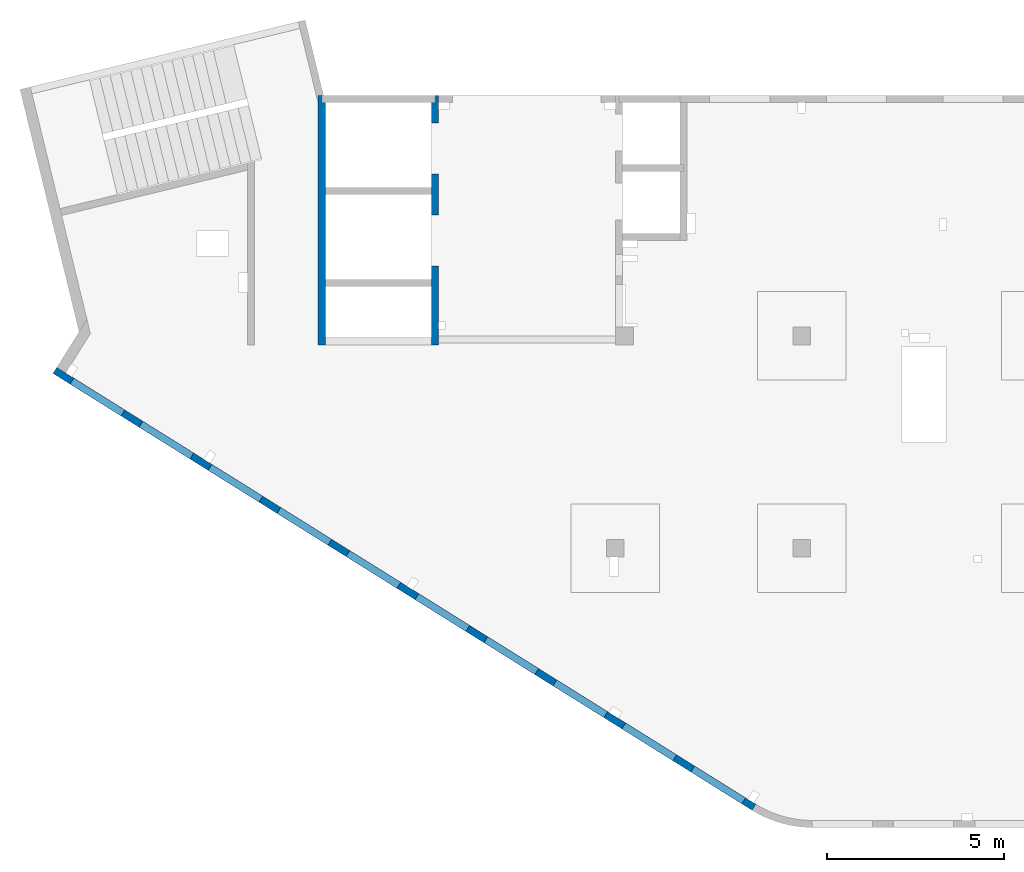
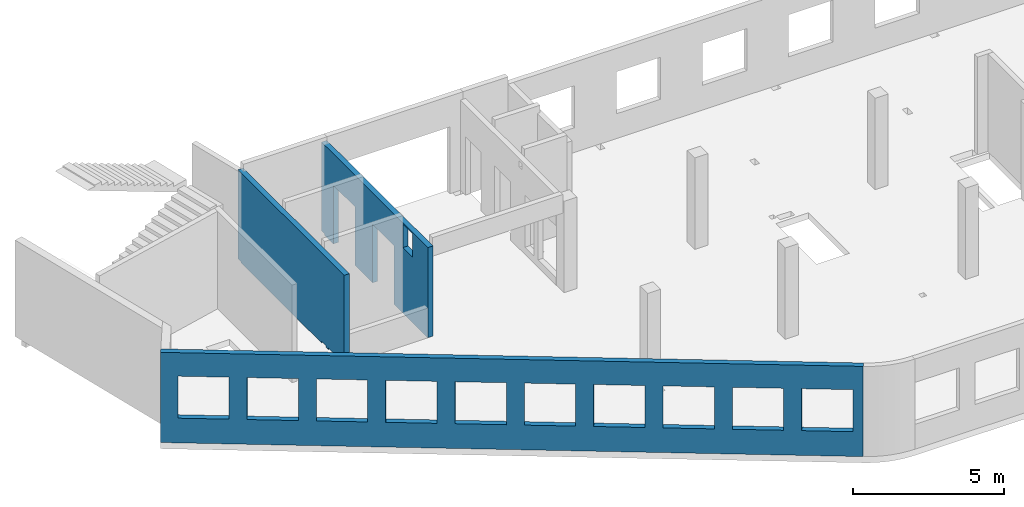
# One storey, part 4 of 7: 3 walls, 17 openings.
"""IFC4 building model written with IfcOpenShell, lengths in millimetres."""

from ifc_helpers import new_model, entity, si_unit, converted_unit, derived_unit, direction, frame, origin, place, context, subcontext, project, spatial, indexed_curve, outline, extrude, polygons, material, type_object, element, save


model = new_model("IFC4")

# Units and contexts
model_context = context("Model", 3, precision=0.01, world=origin(), true_north=direction((6.12303176911189e-17, 1.0)))
plan_context = context("Plan", 3, precision=0.01, world=origin(), true_north=direction((6.12303176911189e-17, 1.0)))
body_context = subcontext(model_context, "Body", "Model", "MODEL_VIEW")
ifc_project = project(units=[si_unit("LENGTHUNIT", "METRE", prefix="MILLI"), si_unit("AREAUNIT", "SQUARE_METRE"), si_unit("VOLUMEUNIT", "CUBIC_METRE"), converted_unit("PLANEANGLEUNIT", "DEGREE", entity("IfcRatioMeasure", 0.0174532925199433), si_unit("PLANEANGLEUNIT", "RADIAN"), dimensions=[0, 0, 0, 0, 0, 0, 0]), si_unit("MASSUNIT", "GRAM", prefix="KILO"), derived_unit("MASSDENSITYUNIT", [(si_unit("MASSUNIT", "GRAM", prefix="KILO"), 1), (si_unit("LENGTHUNIT", "METRE"), -3)]), derived_unit("MOMENTOFINERTIAUNIT", [(si_unit("LENGTHUNIT", "METRE"), 4)]), si_unit("TIMEUNIT", "SECOND"), si_unit("FREQUENCYUNIT", "HERTZ"), si_unit("THERMODYNAMICTEMPERATUREUNIT", "DEGREE_CELSIUS"), derived_unit("THERMALTRANSMITTANCEUNIT", [(si_unit("MASSUNIT", "GRAM", prefix="KILO"), 1), (si_unit("THERMODYNAMICTEMPERATUREUNIT", "KELVIN"), -1), (si_unit("TIMEUNIT", "SECOND"), -3)]), derived_unit("VOLUMETRICFLOWRATEUNIT", [(si_unit("LENGTHUNIT", "METRE"), 3), (si_unit("TIMEUNIT", "SECOND"), -1)]), derived_unit("MASSFLOWRATEUNIT", [(si_unit("MASSUNIT", "GRAM", prefix="KILO"), 1), (si_unit("TIMEUNIT", "SECOND"), -1)]), derived_unit("ROTATIONALFREQUENCYUNIT", [(si_unit("TIMEUNIT", "SECOND"), -1)]), si_unit("ELECTRICCURRENTUNIT", "AMPERE"), si_unit("ELECTRICVOLTAGEUNIT", "VOLT"), si_unit("POWERUNIT", "WATT"), si_unit("FORCEUNIT", "NEWTON", prefix="KILO"), si_unit("ILLUMINANCEUNIT", "LUX"), si_unit("LUMINOUSFLUXUNIT", "LUMEN"), si_unit("LUMINOUSINTENSITYUNIT", "CANDELA"), derived_unit("USERDEFINED", [(si_unit("MASSUNIT", "GRAM", prefix="KILO"), -1), (si_unit("LENGTHUNIT", "METRE"), -2), (si_unit("TIMEUNIT", "SECOND"), 3), (si_unit("LUMINOUSFLUXUNIT", "LUMEN"), 1)]), derived_unit("LINEARVELOCITYUNIT", [(si_unit("LENGTHUNIT", "METRE"), 1), (si_unit("TIMEUNIT", "SECOND"), -1)]), si_unit("PRESSUREUNIT", "PASCAL"), derived_unit("USERDEFINED", [(si_unit("LENGTHUNIT", "METRE"), -2), (si_unit("MASSUNIT", "GRAM", prefix="KILO"), 1), (si_unit("TIMEUNIT", "SECOND"), -2)]), derived_unit("LINEARFORCEUNIT", [(si_unit("MASSUNIT", "GRAM", prefix="KILO"), 1), (si_unit("LENGTHUNIT", "METRE"), 1), (si_unit("TIMEUNIT", "SECOND"), -2), (si_unit("LENGTHUNIT", "METRE"), -1)]), derived_unit("PLANARFORCEUNIT", [(si_unit("MASSUNIT", "GRAM", prefix="KILO"), 1), (si_unit("LENGTHUNIT", "METRE"), 1), (si_unit("TIMEUNIT", "SECOND"), -2), (si_unit("LENGTHUNIT", "METRE"), -2)])], contexts=[model_context, plan_context])

# Site, building, storey
site_placement = place(None, origin())
site = spatial("IfcSite", under=ifc_project, at=site_placement, CompositionType="ELEMENT")
building_placement = place(site_placement, origin())
building = spatial("IfcBuilding", under=site, at=building_placement, CompositionType="ELEMENT")
storey_placement = place(building_placement, frame((0.0, 0.0, 12000.0)))
storey = spatial("IfcBuildingStorey", under=building, at=storey_placement, CompositionType="ELEMENT", Elevation=12000.0)

# Wall, openings
ifc_material = material()
wall_type = type_object("IfcWallType", PredefinedType="STANDARD")
wall_1_placement = place(storey_placement, frame((19822.3508929728, 371.159406986362, -150.0), z_axis=(0.0, 0.0, 1.0), x_axis=(-0.848052743777574, 0.529911826412025, 0.0)))
wall_1 = element("IfcWall", 1, at=wall_1_placement, inside=storey, type_object=wall_type, material=ifc_material, PredefinedType="NOTDEFINED", context=body_context, shape_type="Tessellation", body=[
    polygons([(-1.48894230278529e-12, -99.9999999999978, 0.0), (23011.6394501553, -99.9999999999989, 0.0), (23311.6394501553, -99.9999999999989, 0.0), (23311.6394501553, -99.9999999999989, 3650.0), (23011.6394501553, -99.9999999999989, 3650.0), (-1.48894230278529e-12, -99.9999999999978, 3650.0), (341.63903172165, -99.9999999999988, 2699.99999999999), (2041.63903172165, -99.9999999999981, 2699.99999999999), (2041.63903172165, -99.9999999999981, 1000.00000000001), (341.63903172165, -99.9999999999988, 1000.00000000001), (2641.63903172165, -99.9999999999995, 2699.99999999999), (4341.63903172165, -99.9999999999992, 2699.99999999999), (4341.63903172165, -99.9999999999992, 1000.00000000001), (2641.63903172165, -99.9999999999995, 1000.00000000001), (4941.63903172166, -100.0, 2699.99999999999), (6641.63903172166, -99.9999999999984, 2699.99999999999), (6641.63903172166, -99.9999999999984, 1000.00000000001), (4941.63903172166, -100.0, 1000.00000000001), (7241.63903172167, -99.9999999999984, 2699.99999999999), (8941.63903172167, -100.0, 2699.99999999999), (8941.63903172167, -100.0, 1000.00000000001), (7241.63903172167, -99.9999999999984, 1000.00000000001), (9541.63903172167, -100.0, 2699.99999999999), (11241.6390317217, -99.9999999999989, 2699.99999999999), (11241.6390317217, -99.9999999999989, 1000.00000000001), (9541.63903172167, -100.0, 1000.00000000001), (11841.6390317217, -100.0, 2699.99999999999), (13541.6390317217, -100.0, 2699.99999999999), (13541.6390317217, -100.0, 1000.00000000001), (11841.6390317217, -100.0, 1000.00000000001), (14141.6390317217, -100.0, 2699.99999999999), (15841.6390317217, -100.0, 2699.99999999999), (15841.6390317217, -100.0, 1000.00000000001), (14141.6390317217, -100.0, 1000.00000000001), (16441.6390317217, -99.9999999999989, 2699.99999999999), (18141.6390317217, -99.9999999999989, 2699.99999999999), (18141.6390317217, -99.9999999999989, 1000.00000000001), (16441.6390317217, -99.9999999999989, 1000.00000000001), (18741.6390317217, -100.0, 2699.99999999999), (20441.6390317217, -99.9999999999989, 2699.99999999999), (20441.6390317217, -99.9999999999989, 1000.00000000001), (18741.6390317217, -100.0, 1000.00000000001), (21041.6390317217, -99.9999999999989, 2699.99999999999), (22741.6390317217, -100.000000000001, 2699.99999999999), (22741.6390317217, -100.000000000001, 1000.00000000001), (21041.6390317217, -99.9999999999989, 1000.00000000001), (23311.6394501553, 99.9999999999989, 0.0), (-2.26725305196851e-12, 100.000000000001, 0.0), (-2.26725305196851e-12, 100.000000000001, 3650.0), (23311.6394501553, 100.000000000001, 3650.0), (2041.63903172165, 100.000000000323, 2700.0), (341.63903172165, 100.000000000321, 2700.0), (341.63903172165, 100.000000000321, 1000.00000000001), (2041.63903172165, 100.000000000323, 1000.00000000001), (4341.63903172165, 100.000000000322, 2700.0), (2641.63903172165, 100.00000000032, 2700.0), (2641.63903172165, 100.00000000032, 1000.00000000001), (4341.63903172165, 100.000000000322, 1000.00000000001), (6641.63903172166, 100.000000000322, 2700.0), (4941.63903172166, 100.000000000321, 2700.0), (4941.63903172166, 100.000000000321, 1000.00000000001), (6641.63903172166, 100.000000000322, 1000.00000000001), (8941.63903172166, 100.000000000321, 2700.0), (7241.63903172167, 100.000000000322, 2700.0), (7241.63903172167, 100.000000000322, 1000.00000000001), (8941.63903172166, 100.000000000321, 1000.00000000001), (11241.6390317217, 100.000000000323, 2700.0), (9541.63903172167, 100.000000000321, 2700.0), (9541.63903172167, 100.000000000321, 1000.00000000001), (11241.6390317217, 100.000000000323, 1000.00000000001), (13541.6390317217, 100.000000000319, 2700.0), (11841.6390317217, 100.000000000323, 2700.0), (11841.6390317217, 100.000000000323, 1000.00000000001), (13541.6390317217, 100.000000000319, 1000.00000000001), (15841.6390317217, 100.000000000322, 2700.0), (14141.6390317217, 100.000000000322, 2700.0), (14141.6390317217, 100.000000000322, 1000.00000000001), (15841.6390317217, 100.000000000322, 1000.00000000001), (18141.6390317217, 100.000000000322, 2700.0), (16441.6390317217, 100.000000000322, 2700.0), (16441.6390317217, 100.000000000322, 1000.00000000001), (18141.6390317217, 100.000000000322, 1000.00000000001), (20441.6390317217, 100.000000000322, 2700.0), (18741.6390317217, 100.000000000319, 2700.0), (18741.6390317217, 100.000000000319, 1000.00000000001), (20441.6390317217, 100.000000000322, 1000.00000000001), (22741.6390317217, 100.000000000319, 2700.0), (21041.6390317217, 100.000000000321, 2700.0), (21041.6390317217, 100.000000000323, 1000.00000000001), (22741.6390317217, 100.000000000319, 1000.00000000001)], [[[1, 2, 3, 4, 5, 6], [7, 8, 9, 10], [11, 12, 13, 14], [15, 16, 17, 18], [19, 20, 21, 22], [23, 24, 25, 26], [27, 28, 29, 30], [31, 32, 33, 34], [35, 36, 37, 38], [39, 40, 41, 42], [43, 44, 45, 46]], [[47, 48, 49, 50], [51, 52, 53, 54], [55, 56, 57, 58], [59, 60, 61, 62], [63, 64, 65, 66], [67, 68, 69, 70], [71, 72, 73, 74], [75, 76, 77, 78], [79, 80, 81, 82], [83, 84, 85, 86], [87, 88, 89, 90]], [[3, 2, 1, 48, 47]], [[6, 5, 4, 50, 49]], [[1, 6, 49, 48]], [[4, 3, 47, 50]], [[52, 51, 8, 7]], [[52, 7, 10, 53]], [[53, 10, 9, 54]], [[8, 51, 54, 9]], [[56, 55, 12, 11]], [[56, 11, 14, 57]], [[57, 14, 13, 58]], [[12, 55, 58, 13]], [[60, 59, 16, 15]], [[60, 15, 18, 61]], [[61, 18, 17, 62]], [[16, 59, 62, 17]], [[64, 63, 20, 19]], [[64, 19, 22, 65]], [[65, 22, 21, 66]], [[20, 63, 66, 21]], [[68, 67, 24, 23]], [[68, 23, 26, 69]], [[69, 26, 25, 70]], [[24, 67, 70, 25]], [[72, 71, 28, 27]], [[72, 27, 30, 73]], [[73, 30, 29, 74]], [[28, 71, 74, 29]], [[76, 75, 32, 31]], [[76, 31, 34, 77]], [[77, 34, 33, 78]], [[32, 75, 78, 33]], [[80, 79, 36, 35]], [[80, 35, 38, 81]], [[81, 38, 37, 82]], [[36, 79, 82, 37]], [[84, 83, 40, 39]], [[84, 39, 42, 85]], [[85, 42, 41, 86]], [[40, 83, 86, 41]], [[88, 87, 44, 43]], [[88, 43, 46, 89]], [[89, 46, 45, 90]], [[44, 87, 90, 45]]], closed=True),
])
opening_1_placement = place(wall_1_placement, frame((16613.7173036613, 10818.8609189489, 150.0), z_axis=(0.0, 0.0, 1.0), x_axis=(-0.848052743777574, -0.529911826412026, 0.0)))
element("IfcOpeningElement", 2, at=opening_1_placement, cuts=wall_1, PredefinedType="OPENING", context=body_context, shape_type="SweptSolid", body=[
    extrude(outline(indexed_curve([(-849.999999999993, -850.0), (849.999999999995, -850.0), (849.999999999995, 850.0), (-849.999999999993, 850.0), (-849.999999999993, -850.0)], self_intersect=False)), frame((1310.07752897417, 12056.6031038165, 1700.0), z_axis=(-0.529911826412026, -0.848052743777574, 0.0), x_axis=(0.0, 0.0, -1.0)), (0.0, 0.0, 1.0), 200.000000000964),
])
opening_2_placement = place(wall_1_placement, frame((16613.7173036613, 10818.8609189489, 150.0), z_axis=(0.0, 0.0, 1.0), x_axis=(-0.848052743777574, -0.529911826412026, 0.0)))
element("IfcOpeningElement", 3, at=opening_2_placement, cuts=wall_1, PredefinedType="OPENING", context=body_context, shape_type="SweptSolid", body=[
    extrude(outline(indexed_curve([(-849.999999999993, -850.0), (849.999999999995, -850.0), (849.999999999995, 850.0), (-849.999999999993, 850.0), (-849.999999999993, -850.0)], self_intersect=False)), frame((3260.5988396626, 10837.8059030689, 1700.0), z_axis=(-0.529911826412026, -0.848052743777574, 0.0), x_axis=(0.0, 0.0, -1.0)), (0.0, 0.0, 1.0), 200.000000000964),
])
opening_3_placement = place(wall_1_placement, frame((16613.7173036613, 10818.8609189489, 150.0), z_axis=(0.0, 0.0, 1.0), x_axis=(-0.848052743777574, -0.529911826412026, 0.0)))
element("IfcOpeningElement", 4, at=opening_3_placement, cuts=wall_1, PredefinedType="OPENING", context=body_context, shape_type="SweptSolid", body=[
    extrude(outline(indexed_curve([(-849.999999999993, -850.0), (849.999999999995, -850.0), (849.999999999995, 850.0), (-849.999999999993, 850.0), (-849.999999999993, -850.0)], self_intersect=False)), frame((5211.12015035101, 9619.00870232123, 1700.0), z_axis=(-0.529911826412025, -0.848052743777574, 0.0), x_axis=(0.0, 0.0, -1.0)), (0.0, 0.0, 1.0), 200.000000000962),
])
opening_4_placement = place(wall_1_placement, frame((16613.7173036613, 10818.8609189489, 150.0), z_axis=(0.0, 0.0, 1.0), x_axis=(-0.848052743777574, -0.529911826412026, 0.0)))
element("IfcOpeningElement", 5, at=opening_4_placement, cuts=wall_1, PredefinedType="OPENING", context=body_context, shape_type="SweptSolid", body=[
    extrude(outline(indexed_curve([(-849.999999999993, -849.999999999999), (849.999999999995, -849.999999999999), (849.999999999995, 850.0), (-849.999999999993, 850.0), (-849.999999999993, -849.999999999999)], self_intersect=False)), frame((7161.64146103944, 8400.21150157357, 1700.0), z_axis=(-0.529911826412026, -0.848052743777574, 0.0), x_axis=(0.0, 0.0, -1.0)), (0.0, 0.0, 1.0), 200.000000000962),
])
opening_5_placement = place(wall_1_placement, frame((16613.7173036613, 10818.8609189489, 150.0), z_axis=(0.0, 0.0, 1.0), x_axis=(-0.848052743777574, -0.529911826412026, 0.0)))
element("IfcOpeningElement", 6, at=opening_5_placement, cuts=wall_1, PredefinedType="OPENING", context=body_context, shape_type="SweptSolid", body=[
    extrude(outline(indexed_curve([(-849.999999999993, -849.999999999999), (849.999999999995, -849.999999999999), (849.999999999995, 850.0), (-849.999999999993, 850.0), (-849.999999999993, -849.999999999999)], self_intersect=False)), frame((9112.16277172786, 7181.41430082591, 1700.0), z_axis=(-0.529911826412026, -0.848052743777574, 0.0), x_axis=(0.0, 0.0, -1.0)), (0.0, 0.0, 1.0), 200.000000000962),
])
opening_6_placement = place(wall_1_placement, frame((16613.7173036613, 10818.8609189489, 150.0), z_axis=(0.0, 0.0, 1.0), x_axis=(-0.848052743777574, -0.529911826412026, 0.0)))
element("IfcOpeningElement", 7, at=opening_6_placement, cuts=wall_1, PredefinedType="OPENING", context=body_context, shape_type="SweptSolid", body=[
    extrude(outline(indexed_curve([(-849.999999999993, -850.0), (849.999999999995, -850.0), (849.999999999995, 850.0), (-849.999999999993, 850.0), (-849.999999999993, -850.0)], self_intersect=False)), frame((11062.6840824163, 5962.61710007824, 1700.0), z_axis=(-0.529911826412025, -0.848052743777574, 0.0), x_axis=(0.0, 0.0, -1.0)), (0.0, 0.0, 1.0), 200.000000000964),
])
opening_7_placement = place(wall_1_placement, frame((16613.7173036613, 10818.8609189489, 150.0), z_axis=(0.0, 0.0, 1.0), x_axis=(-0.848052743777574, -0.529911826412026, 0.0)))
element("IfcOpeningElement", 8, at=opening_7_placement, cuts=wall_1, PredefinedType="OPENING", context=body_context, shape_type="SweptSolid", body=[
    extrude(outline(indexed_curve([(-849.999999999993, -850.0), (849.999999999995, -850.0), (849.999999999995, 850.0), (-849.999999999993, 850.0), (-849.999999999993, -850.0)], self_intersect=False)), frame((13013.2053931047, 4743.81989933058, 1700.0), z_axis=(-0.529911826412025, -0.848052743777574, 0.0), x_axis=(0.0, 0.0, -1.0)), (0.0, 0.0, 1.0), 200.000000000959),
])
opening_8_placement = place(wall_1_placement, frame((16613.7173036613, 10818.8609189489, 150.0), z_axis=(0.0, 0.0, 1.0), x_axis=(-0.848052743777574, -0.529911826412026, 0.0)))
element("IfcOpeningElement", 9, at=opening_8_placement, cuts=wall_1, PredefinedType="OPENING", context=body_context, shape_type="SweptSolid", body=[
    extrude(outline(indexed_curve([(-849.999999999993, -850.000000000002), (849.999999999995, -850.000000000002), (849.999999999995, 849.999999999998), (-849.999999999993, 849.999999999998), (-849.999999999993, -850.000000000002)], self_intersect=False)), frame((14963.7267037931, 3525.02269858292, 1700.0), z_axis=(-0.529911826412025, -0.848052743777574, 0.0), x_axis=(0.0, 0.0, -1.0)), (0.0, 0.0, 1.0), 200.000000000962),
])
opening_9_placement = place(wall_1_placement, frame((16613.7173036613, 10818.8609189489, 150.0), z_axis=(0.0, 0.0, 1.0), x_axis=(-0.848052743777574, -0.529911826412026, 0.0)))
element("IfcOpeningElement", 10, at=opening_9_placement, cuts=wall_1, PredefinedType="OPENING", context=body_context, shape_type="SweptSolid", body=[
    extrude(outline(indexed_curve([(-849.999999999993, -850.0), (849.999999999995, -850.0), (849.999999999995, 850.0), (-849.999999999993, 850.0), (-849.999999999993, -850.0)], self_intersect=False)), frame((16914.2480144816, 2306.22549783526, 1700.0), z_axis=(-0.529911826412025, -0.848052743777574, 0.0), x_axis=(0.0, 0.0, -1.0)), (0.0, 0.0, 1.0), 200.000000000962),
])
opening_10_placement = place(wall_1_placement, frame((16613.7173036613, 10818.8609189489, 150.0), z_axis=(0.0, 0.0, 1.0), x_axis=(-0.848052743777574, -0.529911826412026, 0.0)))
element("IfcOpeningElement", 11, at=opening_10_placement, cuts=wall_1, PredefinedType="OPENING", context=body_context, shape_type="SweptSolid", body=[
    extrude(outline(indexed_curve([(-849.999999999993, -850.0), (849.999999999995, -850.0), (849.999999999995, 850.0), (-849.999999999993, 850.0), (-849.999999999993, -850.0)], self_intersect=False)), frame((18864.76932517, 1087.4282970876, 1700.0), z_axis=(-0.529911826412025, -0.848052743777574, 0.0), x_axis=(0.0, 0.0, -1.0)), (0.0, 0.0, 1.0), 200.000000000966),
])

wall_2_placement = place(storey_placement, frame((7600.0002685547, 20499.9998657227, -150.0), z_axis=(0.0, 0.0, 1.0), x_axis=(0.0, -1.0, 0.0)))
wall_2 = element("IfcWall", 12, at=wall_2_placement, inside=storey, type_object=wall_type, material=ifc_material, PredefinedType="NOTDEFINED", context=body_context, shape_type="Tessellation", body=[
    polygons([(7050.0006393668, -99.9999999999996, 3650.0), (226.500105821614, -99.9999999999996, 3650.0), (0.0, -100.000000000001, 3650.0), (0.0, -100.000000000001, 49.9999999999973), (200.000000000002, -100.000000000001, 49.9999999999973), (200.000000000002, -100.000000000001, 0.0), (226.50010582161, -99.9999999999996, 0.0), (5545.0, -100.000000000001, 0.0), (5545.0, -100.000000000001, 59.999999999995), (5855.0, -100.0, 59.999999999995), (5855.0, -100.0, 0.0), (5985.0, -100.0, 0.0), (5985.0, -100.0, 59.999999999995), (6294.99999999999, -99.9999999999997, 59.999999999995), (6294.99999999999, -99.9999999999997, 0.0), (7050.0006393668, -99.9999999999996, 0.0), (0.0, 100.0, 3650.0), (200.000000000002, 100.0, 3650.0), (6850.0006393668, 100.0, 3650.0), (7050.0006393668, 99.9999999999993, 3650.0), (7050.0006393668, 100.0, 1200.0), (7050.0006393668, 99.9999999999993, 0.0), (6850.0006393668, 100.0, 0.0), (6294.99999999999, 100.0, 0.0), (6294.99999999999, 100.000000000321, 59.999999999995), (5985.0, 100.000000000321, 59.999999999995), (5985.0, 100.000000000001, 0.0), (5855.0, 100.000000000001, 0.0), (5855.0, 100.000000000321, 59.999999999995), (5545.0, 100.000000000321, 59.999999999995), (5545.0, 100.0, 0.0), (200.000000000002, 100.0, 0.0), (200.000000000002, 100.0, 49.9999999999973), (0.0, 100.0, 49.9999999999973), (200.000000000002, -6.87656940234796e-13, 0.0), (0.0, 50.6443876577722, 3650.0), (0.0, 7.9044633377313e-14, 3650.0)], [[[1, 2, 3, 4, 5, 6, 7, 8, 9, 10, 11, 12, 13, 14, 15, 16]], [[17, 18, 19, 20, 21, 22, 23, 24, 25, 26, 27, 28, 29, 30, 31, 32, 33, 34]], [[6, 35, 32, 31, 8, 7]], [[3, 2, 1, 20, 19, 18, 17, 36, 37]], [[6, 5, 33, 32, 35]], [[4, 3, 37, 36, 17, 34]], [[13, 26, 25, 14]], [[26, 13, 12, 27]], [[14, 25, 24, 15]], [[9, 30, 29, 10]], [[30, 9, 8, 31]], [[10, 29, 28, 11]], [[34, 33, 5, 4]], [[1, 16, 22, 21, 20]], [[16, 15, 24, 23, 22]], [[27, 12, 11, 28]]], closed=True),
])
opening_11_placement = place(wall_2_placement, origin())
element("IfcOpeningElement", 13, at=opening_11_placement, cuts=wall_2, PredefinedType="OPENING", context=body_context, shape_type="SweptSolid", body=[
    extrude(outline(indexed_curve([(-154.999999999993, -154.999999999999), (154.999999999993, -154.999999999999), (154.999999999993, 154.999999999999), (-154.999999999993, 154.999999999999), (-154.999999999993, -154.999999999999)], self_intersect=False)), frame((6140.0, -100.0, -95.0), z_axis=(0.0, 1.0, 0.0), x_axis=(0.0, 0.0, -1.0)), (0.0, 0.0, 1.0), 200.000000000962),
])
opening_12_placement = place(wall_2_placement, origin())
element("IfcOpeningElement", 14, at=opening_12_placement, cuts=wall_2, PredefinedType="OPENING", context=body_context, shape_type="SweptSolid", body=[
    extrude(outline(indexed_curve([(-154.999999999993, -154.999999999999), (154.999999999993, -154.999999999999), (154.999999999993, 154.999999999999), (-154.999999999993, 154.999999999999), (-154.999999999993, -154.999999999999)], self_intersect=False)), frame((5700.0, -100.0, -95.0), z_axis=(0.0, 1.0, 0.0), x_axis=(0.0, 0.0, -1.0)), (0.0, 0.0, 1.0), 200.000000000962),
])
opening_13_placement = place(wall_2_placement, frame((20499.9998657227, -7600.0002685547, 150.0), z_axis=(0.0, 0.0, 1.0), x_axis=(0.0, 1.0, 0.0)))
element("IfcOpeningElement", 15, at=opening_13_placement, cuts=wall_2, PredefinedType="OPENING", context=body_context, shape_type="SweptSolid", body=[
    extrude(outline(indexed_curve([(-154.999999999995, -154.999999999999), (154.999999999991, -154.999999999999), (154.999999999991, 154.999999999999), (-154.999999999995, 154.999999999999), (-154.999999999995, -154.999999999999)], self_intersect=False)), frame((7500.00026855469, 14359.9998657227, 3655.0), z_axis=(1.0, 0.0, 0.0), x_axis=(0.0, 0.0, -1.0)), (0.0, 0.0, 1.0), 200.000000000962),
])
opening_14_placement = place(wall_2_placement, frame((20499.9998657227, -7600.0002685547, 150.0), z_axis=(0.0, 0.0, 1.0), x_axis=(0.0, 1.0, 0.0)))
element("IfcOpeningElement", 16, at=opening_14_placement, cuts=wall_2, PredefinedType="OPENING", context=body_context, shape_type="SweptSolid", body=[
    extrude(outline(indexed_curve([(-154.999999999995, -154.999999999999), (154.999999999991, -154.999999999999), (154.999999999991, 154.999999999999), (-154.999999999995, 154.999999999999), (-154.999999999995, -154.999999999999)], self_intersect=False)), frame((7500.00026855469, 14799.9998657227, 3655.0), z_axis=(1.0, 0.0, 0.0), x_axis=(0.0, 0.0, -1.0)), (0.0, 0.0, 1.0), 200.000000000962),
])

wall_3_placement = place(storey_placement, frame((10800.0002685547, 20499.9998657227, -150.0), z_axis=(0.0, 0.0, 1.0), x_axis=(0.0, -1.0, 0.0)))
wall_3 = element("IfcWall", 17, at=wall_3_placement, inside=storey, type_object=wall_type, material=ifc_material, PredefinedType="NOTDEFINED", context=body_context, shape_type="Tessellation", body=[
    polygons([(5400.00000000002, -99.999999999999, 3600.0), (6050.00000000002, -99.9999999999979, 3600.0), (6050.00000000002, -99.9999999999979, 2650.00000000001), (5400.00000000002, -99.999999999999, 2650.00000000001), (7050.00063936683, -99.9999999999985, 3650.0), (6850.00063936682, -99.9999999999988, 3650.0), (200.000000000028, -99.9999999999985, 3650.0), (0.0, -99.9999999999988, 3650.0), (0.0, -99.9999999999988, 49.9999999999973), (200.000000000028, -99.9999999999985, 49.9999999999973), (200.000000000028, -99.9999999999985, 0.0), (780.000000000018, -99.9999999999976, 0.0), (780.000000000018, -99.9999999999976, 2369.99999999804), (2220.00000000001, -99.9999999999975, 2369.99999999804), (2220.00000000001, -99.9999999999975, 0.0), (3380.00000000002, -99.9999999999978, 0.0), (3380.00000000002, -99.9999999999978, 2369.99999999804), (4820.00000000001, -99.9999999999977, 2369.99999999804), (4820.00000000001, -99.9999999999977, 0.0), (6850.00063936683, -99.9999999999988, 0.0), (7050.00063936683, -99.9999999999985, 0.0), (7050.00063936683, -99.9999999999985, 1200.0), (0.0, 100.000000000001, 3650.0), (200.000000000002, 100.000000000001, 3650.0), (400.00000000003, 100.000000000002, 3650.0), (6400.00063936682, 100.0, 3650.0), (6600.00063936682, 100.000000000001, 3650.0), (7050.00063936683, 100.000000000001, 3650.0), (7050.00063936683, 100.000000000001, 0.0), (6600.00063936682, 100.000000000001, 0.0), (6400.00063936682, 100.0, 0.0), (4820.00000000001, 100.000000000002, 0.0), (4820.00000000002, 100.000000000002, 2369.99999999804), (3380.00000000002, 100.000000000002, 2369.99999999804), (3380.00000000002, 100.000000000002, 0.0), (2220.00000000001, 100.000000000003, 0.0), (2220.00000000001, 100.000000000003, 2369.99999999804), (780.000000000018, 100.000000000002, 2369.99999999804), (780.000000000018, 100.000000000002, 0.0), (400.00000000003, 100.000000000002, 0.0), (200.000000000028, 100.000000000001, 0.0), (200.000000000028, 100.000000000001, 49.9999999999973), (0.0, 100.000000000001, 49.9999999999973), (6050.00000000002, 100.000000000323, 3600.0), (5400.00000000002, 100.000000000322, 3600.0), (5400.00000000002, 100.000000000322, 2650.00000000001), (6050.00000000002, 100.000000000323, 2650.00000000001), (0.0, 7.90446333772861e-14, 3650.0), (200.000000000028, 3.95210189063612e-13, 49.9999999999973), (0.0, 7.90446333772861e-14, 49.9999999999973)], [[[5, 6, 7, 8, 9, 10, 11, 12, 13, 14, 15, 16, 17, 18, 19, 20, 21, 22], [1, 2, 3, 4]], [[23, 24, 25, 26, 27, 28, 29, 30, 31, 32, 33, 34, 35, 36, 37, 38, 39, 40, 41, 42, 43], [44, 45, 46, 47]], [[12, 11, 41, 40, 39]], [[8, 7, 6, 5, 28, 27, 26, 25, 24, 23, 48]], [[45, 44, 2, 1]], [[45, 1, 4, 46]], [[46, 4, 3, 47]], [[2, 44, 47, 3]], [[13, 38, 37, 14]], [[14, 37, 36, 15]], [[38, 13, 12, 39]], [[33, 18, 17, 34]], [[34, 17, 16, 35]], [[18, 33, 32, 19]], [[43, 42, 49, 10, 9, 50]], [[11, 10, 49, 42, 41]], [[9, 8, 48, 23, 43, 50]], [[5, 22, 21, 29, 28]], [[15, 36, 35, 16]], [[29, 21, 20, 19, 32, 31, 30]]], closed=True),
])
opening_15_placement = place(wall_3_placement, frame((20499.9998657227, -10800.0002685547, 150.0), z_axis=(0.0, 0.0, 1.0), x_axis=(0.0, 1.0, 0.0)))
element("IfcOpeningElement", 18, at=opening_15_placement, cuts=wall_3, PredefinedType="OPENING", context=body_context, shape_type="SweptSolid", body=[
    extrude(outline(indexed_curve([(-719.999999999999, -1184.99999999902), (719.999999999999, -1184.99999999902), (719.999999999999, 1184.99999999902), (-719.999999999999, 1184.99999999902), (-719.999999999999, -1184.99999999902)], self_intersect=False)), frame((10600.0002685528, 18999.9998657227, 1035.0), z_axis=(1.0, 0.0, 0.0), x_axis=(0.0, -1.0, 0.0)), (0.0, 0.0, 1.0), 400.000000001943),
])
opening_16_placement = place(wall_3_placement, frame((20499.9998657227, -10800.0002685547, 150.0), z_axis=(0.0, 0.0, 1.0), x_axis=(0.0, 1.0, 0.0)))
element("IfcOpeningElement", 19, at=opening_16_placement, cuts=wall_3, PredefinedType="OPENING", context=body_context, shape_type="SweptSolid", body=[
    extrude(outline(indexed_curve([(-1184.99999999902, -719.999999999999), (1184.99999999902, -719.999999999999), (1184.99999999902, 720.000000000001), (-1184.99999999902, 720.000000000001), (-1184.99999999902, -719.999999999999)], self_intersect=False)), frame((10600.0002685547, 16399.9998657227, 1035.0), z_axis=(1.0, 0.0, 0.0), x_axis=(0.0, 0.0, -1.0)), (0.0, 0.0, 1.0), 400.000000001943),
])
opening_17_placement = place(wall_3_placement, frame((20499.9998657227, -10800.0002685547, 150.0), z_axis=(0.0, 0.0, 1.0), x_axis=(0.0, 1.0, 0.0)))
element("IfcOpeningElement", 20, at=opening_17_placement, cuts=wall_3, PredefinedType="OPENING", context=body_context, shape_type="SweptSolid", body=[
    extrude(outline(indexed_curve([(-474.999999999994, -325.0), (474.999999999992, -325.0), (474.999999999992, 325.0), (-474.999999999994, 325.0), (-474.999999999994, -325.0)], self_intersect=False)), frame((10700.0002685547, 14774.9998657227, 2975.0), z_axis=(1.0, 0.0, 0.0), x_axis=(0.0, 0.0, -1.0)), (0.0, 0.0, 1.0), 200.000000000962),
])

save(model, "model.ifc")
